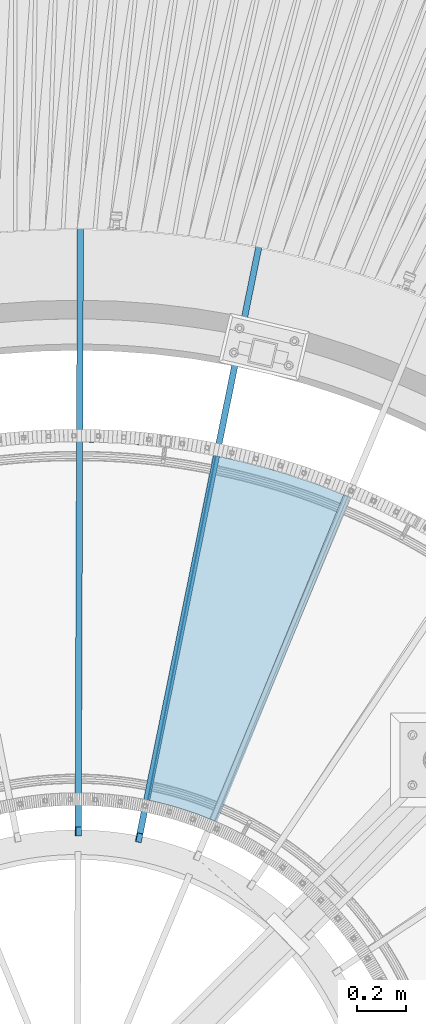
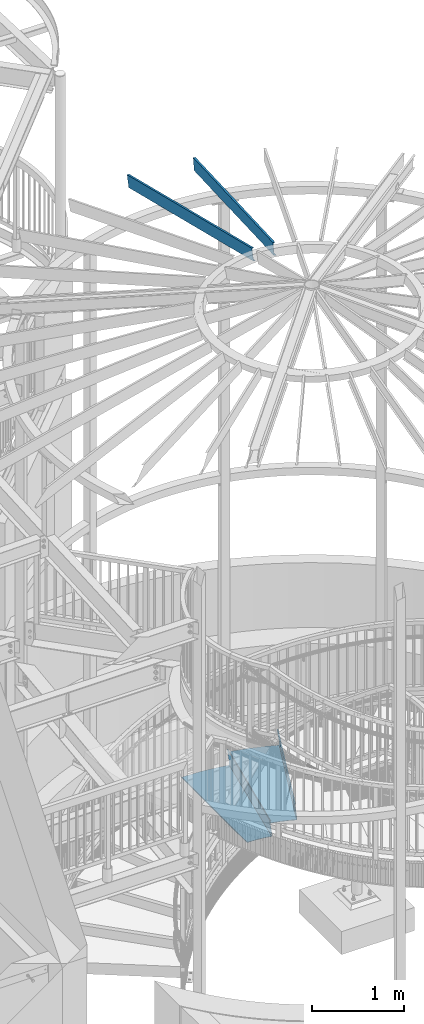
# One storey, part 355 of 975: 4 beams.
"""IFC2X3 building model written with IfcOpenShell, lengths in millimetres."""

from ifc_helpers import new_model, si_unit, frame, origin_with_axes, place, context, subcontext, project, spatial, faceted_brep, material, type_object, element, save


model = new_model("IFC2X3")

# Units and contexts
model_context = context("Model", 3, precision=1e-05, world=origin_with_axes())
body_context = subcontext(model_context, "Body", "Model", "MODEL_VIEW")
ifc_project = project(units=[si_unit("LENGTHUNIT", "METRE", prefix="MILLI"), si_unit("AREAUNIT", "SQUARE_METRE"), si_unit("VOLUMEUNIT", "CUBIC_METRE"), si_unit("MASSUNIT", "GRAM", prefix="KILO"), si_unit("TIMEUNIT", "SECOND"), si_unit("PLANEANGLEUNIT", "RADIAN"), si_unit("SOLIDANGLEUNIT", "STERADIAN"), si_unit("THERMODYNAMICTEMPERATUREUNIT", "DEGREE_CELSIUS"), si_unit("LUMINOUSINTENSITYUNIT", "LUMEN")], contexts=[model_context])

# Site, building, storey
site_placement = place(None, origin_with_axes())
site = spatial("IfcSite", under=ifc_project, at=site_placement, CompositionType="ELEMENT")
building_placement = place(site_placement, origin_with_axes())
building = spatial("IfcBuilding", under=site, at=building_placement, Name="Undefined", CompositionType="ELEMENT")
storey_placement = place(building_placement, origin_with_axes())
storey = spatial("IfcBuildingStorey", under=building, at=storey_placement, Name="Undefined", CompositionType="ELEMENT", Elevation=0.0)

# Beams
ifc_material_1 = material(Name="STEEL/A36")
beam_type_1 = type_object("IfcBeamType", PredefinedType="NOTDEFINED")
beam_1_placement = place(storey_placement, frame((35582.1108977523, 5423.11966252615, 1403.31695574219), z_axis=(0.379904198926888, 0.925025837281165, 1.74446540768258e-10), x_axis=(-0.654092042266831, 0.268632835109608, 0.707106781288498)))
element("IfcBeam", 1, at=beam_1_placement, inside=storey, type_object=beam_type_1, material=ifc_material_1, Name="TREAD", context=body_context, shape_type="Brep", body=[
    faceted_brep([(25.4000001621371, 1.5874997143419, 653.28751700326), (1.61144271260127e-08, 1.58750000026703, 653.458911680114), (-1.96268956642598e-08, -1.58749999973588, 653.437487347819), (15.8745748038546, -1.5875001784334, 653.330368544412), (-120.373022221533, -103.76749224318, 653.560250726816), (-154.208562872085, -137.603032237963, 653.560249286144), (-49.0005534961238, -242.811041643061, 652.140399877677), (-46.7554894721361, -240.565977619684, 652.140399877557), (-149.718432901582, -137.603030988068, 653.529952160912), (-118.287540217565, -106.172138299769, 653.529952144057), (82.2634121742994, -374.075007349978, 638.193006315465), (84.508476198167, -371.829943326711, 638.193006315345), (212.601306559884, -504.412901568812, 612.134347567509), (214.846370562875, -502.167837565145, 612.134347570151), (261.055176792581, -530.596712595621, 601.111823144849), (259.197053542079, -528.103470062568, 601.754434690294), (248.701623596196, -536.023091227627, 602.134831213494), (248.362633442506, -540.174228440612, 601.571851715846), (250.921725105154, -538.24319290819, 601.479100122608), (25.4000001865188, 1.58749971376164, -768.618736200977), (-118.287540216395, -106.172138302336, -768.542582766611), (-149.718433278054, -137.603031368186, -768.542582749815), (-92.8426928760819, -194.478774201189, -768.783692225286), (-95.087756899542, -196.723838224048, -768.783692225159), (-154.208562871598, -137.603032235413, -768.533065523057), (-120.373022220361, -103.767492245748, -768.533065418116), (15.8745748282345, -1.58750017901184, -768.605275732323), (-1.58015609486029e-08, -1.58750000031432, -768.571627720263), (1.99397618416697e-08, 1.58749999968677, -768.564897939472), (-21.2434099455131, -266.078057151808, -776.330856581004), (-23.4884739689005, -268.323121174595, -776.330856580884), (49.7927349215133, -337.114201961485, -791.08236047571), (47.5476709198538, -339.35926596382, -791.082360478347), (66.437802308692, -335.979336534963, -793.502619428495), (56.3071310127107, -343.628597994977, -793.115412720523), (53.7487404151489, -345.560335457225, -793.01762786691), (54.0919957188744, -341.413461775162, -792.424099714608), (64.5845451579717, -333.490960101732, -792.825137753654)], [[[0, 1, 2, 3, 4, 5, 6, 7, 8, 9]], [[7, 6, 10, 11]], [[11, 10, 12, 13]], [[14, 15, 16, 13, 12, 17, 18]], [[19, 20, 21, 22, 23, 24, 25, 26, 27, 28]], [[29, 30, 23, 22]], [[31, 32, 30, 29]], [[33, 34, 35, 32, 31, 36, 37]], [[34, 33, 14, 18]], [[35, 34, 18, 17]], [[10, 6, 5, 24, 23, 30, 32, 35, 17, 12]], [[25, 24, 5, 4]], [[26, 25, 4, 3]], [[27, 26, 3, 2]], [[28, 27, 2, 1]], [[19, 28, 1, 0]], [[20, 19, 0, 9]], [[20, 9, 8, 21]], [[36, 31, 29, 22, 21, 8, 7, 11, 13, 16]], [[37, 36, 16, 15]], [[33, 37, 15, 14]]]),
])
beam_2_placement = place(storey_placement, frame((35175.0562810523, 5549.01699082374, 1225.51695574218), z_axis=(0.193613657155722, 0.981077852039677, -1.45093054015888e-10), x_axis=(-0.693726802106193, 0.136905530020964, 0.707106781108196)))
element("IfcBeam", 2, at=beam_2_placement, inside=storey, type_object=beam_type_1, material=ifc_material_1, Name="TREAD", context=body_context, shape_type="Brep", body=[
    faceted_brep([(25.4000001621371, 1.5874997143419, 653.28751700326), (1.61144271260127e-08, 1.58750000026703, 653.458911680114), (-1.96268956642598e-08, -1.58749999973588, 653.437487347819), (15.8745748038546, -1.5875001784334, 653.330368544412), (-120.373022221533, -103.76749224318, 653.560250726816), (-154.208562872085, -137.603032237963, 653.560249286144), (-49.0005534961238, -242.811041643061, 652.140399877677), (-46.7554894721361, -240.565977619684, 652.140399877557), (-149.718432901582, -137.603030988068, 653.529952160912), (-118.287540217565, -106.172138299769, 653.529952144057), (82.2634121742994, -374.075007349978, 638.193006315465), (84.508476198167, -371.829943326711, 638.193006315345), (212.601306559884, -504.412901568812, 612.134347567509), (214.846370562875, -502.167837565145, 612.134347570151), (261.055176792581, -530.596712595621, 601.111823144849), (259.197053542079, -528.103470062568, 601.754434690294), (248.701623596196, -536.023091227627, 602.134831213494), (248.362633442506, -540.174228440612, 601.571851715846), (250.921725105154, -538.24319290819, 601.479100122608), (25.4000001865188, 1.58749971376164, -768.618736200977), (-118.287540216395, -106.172138302336, -768.542582766611), (-149.718433278054, -137.603031368186, -768.542582749815), (-92.8426928760819, -194.478774201189, -768.783692225286), (-95.087756899542, -196.723838224048, -768.783692225159), (-154.208562871598, -137.603032235413, -768.533065523057), (-120.373022220361, -103.767492245748, -768.533065418116), (15.8745748282345, -1.58750017901184, -768.605275732323), (-1.58015609486029e-08, -1.58750000031432, -768.571627720263), (1.99397618416697e-08, 1.58749999968677, -768.564897939472), (-21.2434099455131, -266.078057151808, -776.330856581004), (-23.4884739689005, -268.323121174595, -776.330856580884), (49.7927349215133, -337.114201961485, -791.08236047571), (47.5476709198538, -339.35926596382, -791.082360478347), (66.437802308692, -335.979336534963, -793.502619428495), (56.3071310127107, -343.628597994977, -793.115412720523), (53.7487404151489, -345.560335457225, -793.01762786691), (54.0919957188744, -341.413461775162, -792.424099714608), (64.5845451579717, -333.490960101732, -792.825137753654)], [[[0, 1, 2, 3, 4, 5, 6, 7, 8, 9]], [[7, 6, 10, 11]], [[11, 10, 12, 13]], [[14, 15, 16, 13, 12, 17, 18]], [[19, 20, 21, 22, 23, 24, 25, 26, 27, 28]], [[29, 30, 23, 22]], [[31, 32, 30, 29]], [[33, 34, 35, 32, 31, 36, 37]], [[34, 33, 14, 18]], [[35, 34, 18, 17]], [[10, 6, 5, 24, 23, 30, 32, 35, 17, 12]], [[25, 24, 5, 4]], [[26, 25, 4, 3]], [[27, 26, 3, 2]], [[28, 27, 2, 1]], [[19, 28, 1, 0]], [[20, 19, 0, 9]], [[20, 9, 8, 21]], [[36, 31, 29, 22, 21, 8, 7, 11, 13, 16]], [[37, 36, 16, 15]], [[33, 37, 15, 14]]]),
])
ifc_material_2 = material(Name="STEEL/Zero_Density")
beam_type_2 = type_object("IfcBeamType", PredefinedType="NOTDEFINED")
for number, where, z_axis, x_axis, name in (
    (3, (34985.6162518173, 4644.05442020445, 8885.0313138005), (0.0481888419808747, 0.237706597905655, 0.97014092214516), (0.192750037960069, 0.950800100803031, -0.242541936949754), "STUD"),
    (4, (34738.7904711684, 4669.20978677817, 8885.0313138005), (0.000888649999629706, 0.242540308898346, 0.970140922165782), (0.00355450199805182, 0.970134410469095, -0.24254193686727), "STUD"),
):
    element("IfcBeam", number, at=place(storey_placement, frame(where, z_axis=z_axis, x_axis=x_axis)), inside=storey, type_object=beam_type_2, material=ifc_material_2, Name=name, context=body_context, shape_type="Brep", body=[
        faceted_brep([(-1.67347025126219e-10, 12.6999999998588, -76.2000000000985), (1.96450855582952e-10, 12.7000000001644, 76.2000000001021), (2798.98467503002, 12.7000000041553, 76.2000000028588), (2798.98467502966, 12.7000000038533, -76.1999999973427), (1.74622982740402e-10, -12.6999999998661, 76.2000000000985), (2798.98467503, -12.6999999958753, 76.2000000028534), (1.67347025126219e-10, -12.6999999998698, 73.0250000000947), (2798.98467502999, -12.6999999958789, 73.0250000028504), (1.89174897968769e-10, 9.52500000015425, 73.0250000000974), (2798.98467503001, 9.52500000414511, 73.0250000028532), (-1.60071067512035e-10, 9.52499999986321, -73.0250000000938), (2798.98467502966, 9.52500000385407, -73.0249999973398), (-1.81898940354586e-10, -12.7000000001608, -73.0250000000965), (2798.98467502964, -12.6999999961699, -73.0249999973416), (-1.92812876775861e-10, -12.7000000001717, -76.2000000001003), (2798.98467502963, -12.6999999961772, -76.1999999973455)], [[[0, 1, 2, 3]], [[1, 4, 5, 2]], [[4, 6, 7, 5]], [[6, 8, 9, 7]], [[8, 10, 11, 9]], [[10, 12, 13, 11]], [[12, 14, 15, 13]], [[14, 0, 3, 15]], [[5, 7, 9, 11, 13, 15, 3, 2]], [[14, 12, 10, 8, 6, 4, 1, 0]]]),
    ])

save(model, "model.ifc")
